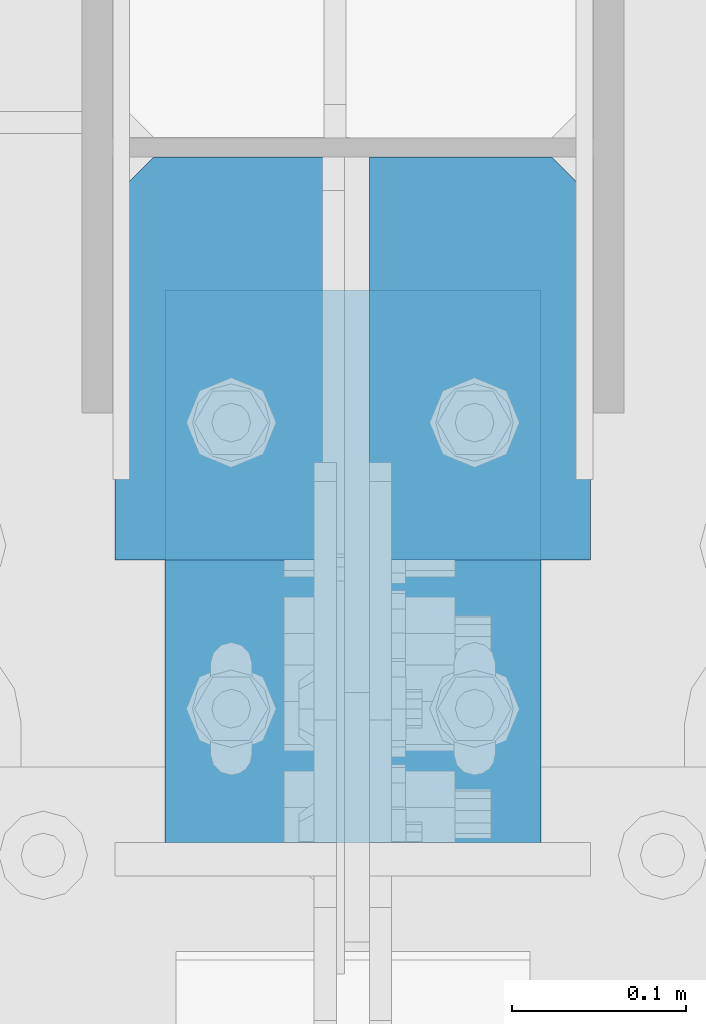
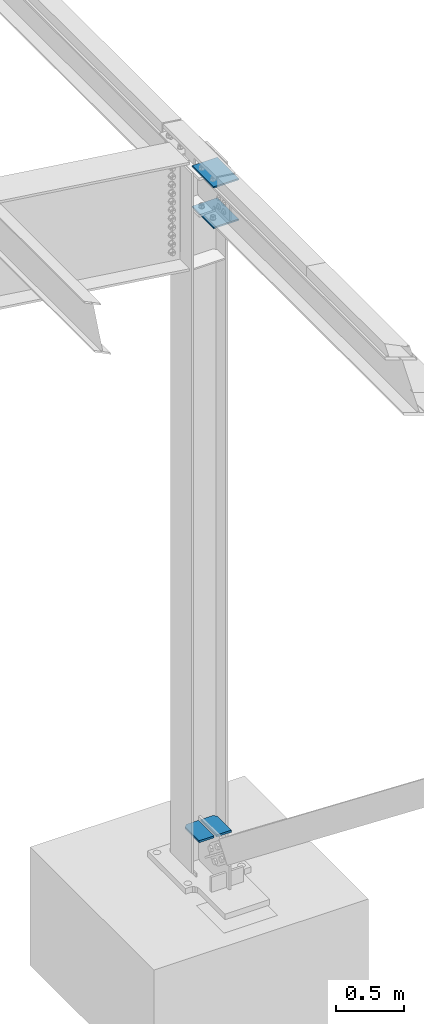
# One storey, part 856 of 1179: 4 beams, 3 elements without a shape of their own.
"""IFC2X3 building model written with IfcOpenShell, lengths in millimetres."""

from ifc_helpers import new_model, si_unit, frame, origin_with_axes, place, context, subcontext, project, spatial, faceted_brep, material, type_object, element, aggregate, save


model = new_model("IFC2X3")

# Units and contexts
model_context = context("Model", 3, precision=1e-05, world=origin_with_axes())
body_context = subcontext(model_context, "Body", "Model", "MODEL_VIEW")
ifc_project = project(units=[si_unit("LENGTHUNIT", "METRE", prefix="MILLI"), si_unit("AREAUNIT", "SQUARE_METRE"), si_unit("VOLUMEUNIT", "CUBIC_METRE"), si_unit("MASSUNIT", "GRAM", prefix="KILO"), si_unit("TIMEUNIT", "SECOND"), si_unit("PLANEANGLEUNIT", "RADIAN"), si_unit("SOLIDANGLEUNIT", "STERADIAN"), si_unit("THERMODYNAMICTEMPERATUREUNIT", "DEGREE_CELSIUS"), si_unit("LUMINOUSINTENSITYUNIT", "LUMEN")], contexts=[model_context])

# Site, building, storey
site_placement = place(None, origin_with_axes())
site = spatial("IfcSite", under=ifc_project, at=site_placement, CompositionType="ELEMENT")
building_placement = place(site_placement, origin_with_axes())
building = spatial("IfcBuilding", under=site, at=building_placement, Name="Undefined", CompositionType="ELEMENT")
storey_placement = place(building_placement, origin_with_axes())
storey = spatial("IfcBuildingStorey", under=building, at=storey_placement, Name="Undefined", CompositionType="ELEMENT", Elevation=0.0)

# Assembly, beams
assembly_1_placement = place(storey_placement, origin_with_axes())
assembly_1 = element("IfcElementAssembly", 1, at=assembly_1_placement, inside=storey, Name="COLUMN", AssemblyPlace="NOTDEFINED", PredefinedType="RIGID_FRAME")
ifc_material = material(Name="STEEL/A572-GR.50")
beam_type_1 = type_object("IfcBeamType", PredefinedType="NOTDEFINED")
beam_1_placement = place(assembly_1_placement, frame((38074.6, 26651.74375, 5737.225), z_axis=(1.0, 0.0, 0.0), x_axis=(0.0, 1.0, 0.0)))
beam_1 = element("IfcBeam", 2, at=beam_1_placement, type_object=beam_type_1, material=ifc_material, Name="PLATE", context=body_context, shape_type="Brep", body=[
    faceted_brep([(0.0, 6.35000000000036, -107.949999999997), (0.0, 6.35000000000036, 107.949999999997), (317.5, 6.35000000000036, 107.949999999997), (317.5, 6.35000000000036, -107.949999999997), (0.0, -6.35000000000036, 107.949999999997), (317.5, -6.35000000000036, 107.949999999997), (0.0, -6.35000000000036, -107.949999999997), (317.5, -6.35000000000036, -107.949999999997)], [[[0, 1, 2, 3]], [[1, 4, 5, 2]], [[4, 6, 7, 5]], [[6, 0, 3, 7]], [[5, 7, 3, 2]], [[6, 4, 1, 0]]]),
])
beam_2_placement = place(assembly_1_placement, frame((38074.6, 26651.74375, 6102.35), z_axis=(1.0, 0.0, 0.0), x_axis=(0.0, 1.0, 0.0)))
beam_2 = element("IfcBeam", 3, at=beam_2_placement, type_object=beam_type_1, material=ifc_material, Name="PLATE", context=body_context, shape_type="Brep", body=[
    faceted_brep([(0.0, 6.35000000000036, -107.949999999997), (0.0, 6.35000000000036, 107.949999999997), (317.5, 6.35000000000036, 107.949999999997), (317.5, 6.35000000000036, -107.949999999997), (0.0, -6.35000000000036, 107.949999999997), (317.5, -6.35000000000036, 107.949999999997), (0.0, -6.35000000000036, -107.949999999997), (317.5, -6.35000000000036, -107.949999999997)], [[[0, 1, 2, 3]], [[1, 4, 5, 2]], [[4, 6, 7, 5]], [[6, 0, 3, 7]], [[5, 7, 3, 2]], [[6, 4, 1, 0]]]),
])
aggregate(assembly_1, [beam_1, beam_2])

# Assembly, beam
assembly_2_placement = place(storey_placement, origin_with_axes())
assembly_2 = element("IfcElementAssembly", 4, at=assembly_2_placement, inside=storey, Name="PLATE", AssemblyPlace="NOTDEFINED", PredefinedType="RIGID_FRAME")
beam_type_2 = type_object("IfcBeamType", PredefinedType="NOTDEFINED")
beam_3_placement = place(assembly_2_placement, frame((38147.625, 26814.1598493745, 117.193043692452), z_axis=(1.0, 0.0, 0.0), x_axis=(0.0, 1.0, 0.0)))
beam_3 = element("IfcBeam", 5, at=beam_3_placement, type_object=beam_type_2, material=ifc_material, Name="PLATE", context=body_context, shape_type="Brep", body=[
    faceted_brep([(209.058903883029, -9.52499999999958, 63.5), (231.283903883032, -9.52499999999952, 41.2750000000015), (231.283903883039, 9.5250000000006, 41.2750000000015), (209.05890388304, 9.52500000000056, 63.5), (231.283903883039, 9.5250000000006, -63.5), (0.0, 9.52500000000146, -63.5), (0.0, 9.52500000000146, 63.5), (0.0, -9.52500000000146, 63.5), (0.0, -9.52500000000146, -63.5), (231.283903883032, -9.52499999999952, -63.5)], [[[0, 1, 2, 3]], [[4, 5, 6, 3, 2]], [[6, 7, 0, 3]], [[7, 8, 9, 1, 0]], [[8, 5, 4, 9]], [[9, 4, 2, 1]], [[8, 7, 6, 5]]]),
])
aggregate(assembly_2, [beam_3])

assembly_3_placement = place(storey_placement, origin_with_axes())
assembly_3 = element("IfcElementAssembly", 6, at=assembly_3_placement, inside=storey, Name="PLATE", AssemblyPlace="NOTDEFINED", PredefinedType="RIGID_FRAME")
beam_4_placement = place(assembly_3_placement, frame((38001.575, 26814.1598504604, 117.193043692452), z_axis=(1.0, 0.0, 0.0), x_axis=(0.0, 1.0, 0.0)))
beam_4 = element("IfcBeam", 7, at=beam_4_placement, type_object=beam_type_2, material=ifc_material, Name="PLATE", context=body_context, shape_type="Brep", body=[
    faceted_brep([(231.283903883032, -9.52499999999952, -41.2750000000015), (209.058903883029, -9.52499999999958, -63.5), (209.05890388304, 9.52500000000056, -63.5), (231.283903883039, 9.52500000000062, -41.2750000000015), (0.0, 9.52500000000146, -63.5), (0.0, 9.52500000000146, 63.5), (231.283903883039, 9.52500000000062, 63.5), (0.0, -9.52500000000146, 63.5), (231.283903883032, -9.52499999999952, 63.5), (0.0, -9.52500000000146, -63.5)], [[[0, 1, 2, 3]], [[4, 5, 6, 3, 2]], [[5, 7, 8, 6]], [[8, 7, 9, 1, 0]], [[9, 4, 2, 1]], [[6, 8, 0, 3]], [[9, 7, 5, 4]]]),
])
aggregate(assembly_3, [beam_4])

save(model, "model.ifc")
